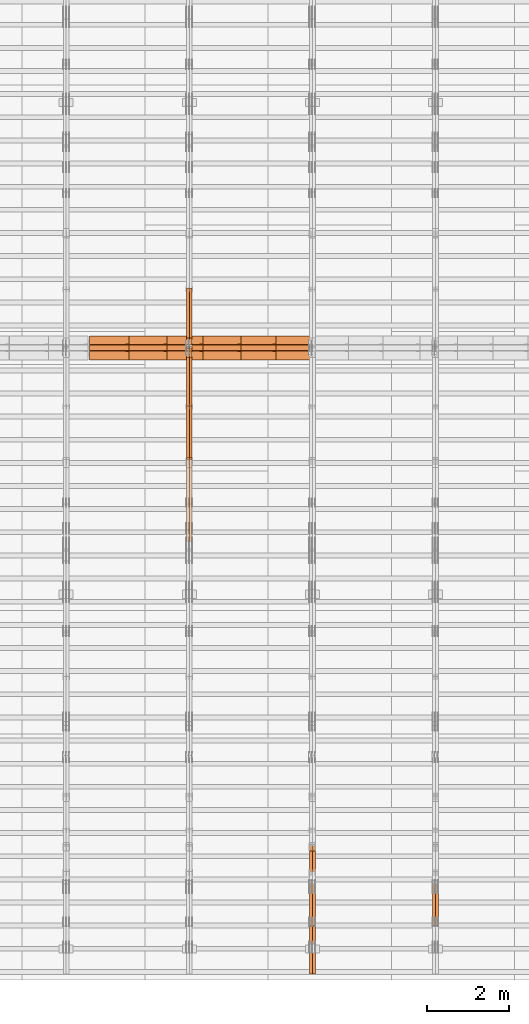
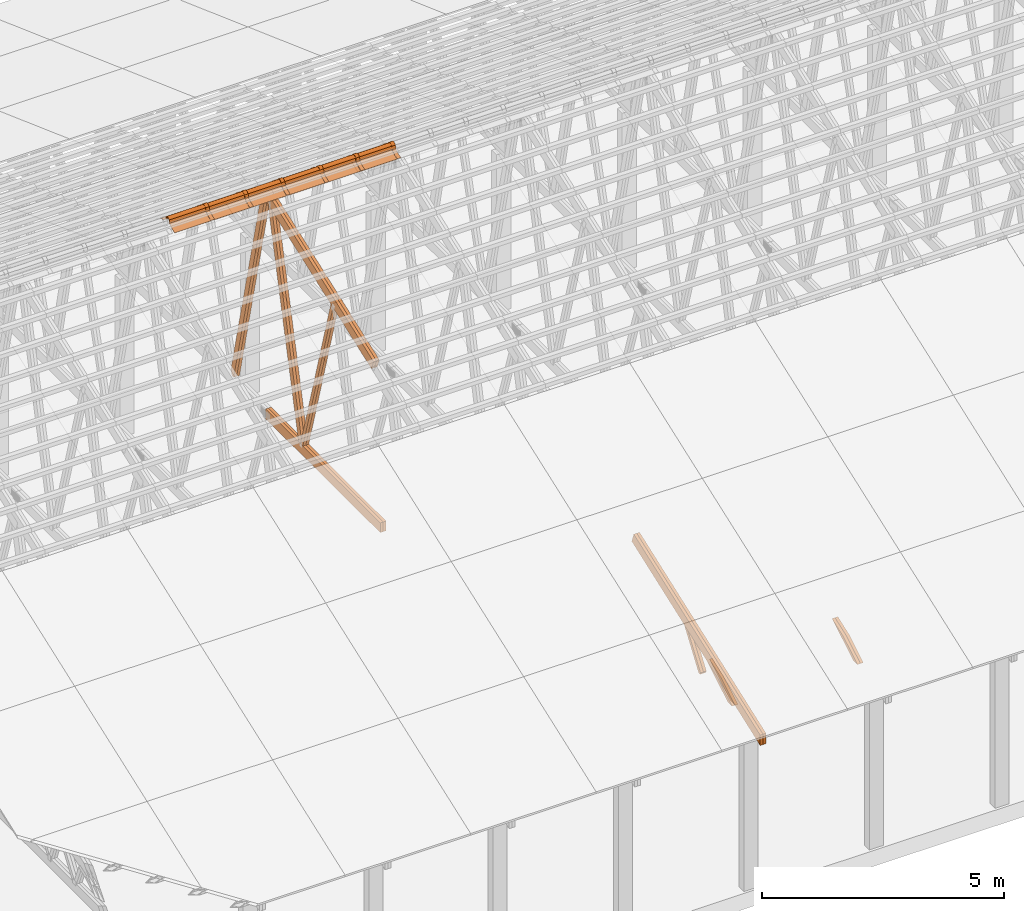
# One storey, part 20 of 189: 30 proxies.
"""IFC2X3 building model written with IfcOpenShell, lengths in millimetres."""

from ifc_helpers import new_model, entity, si_unit, converted_unit, derived_unit, direction, frame, frame_2d, origin, origin_2d_with_axis, place, context, subcontext, project, spatial, polyline, circle_curve, parameter, trimmed, segment, composite_curve, rectangle, outline, extrude, source, transform, mapped, material, type_object, type_shapes, element, save


model = new_model("IFC2X3")

# Units and contexts
model_context = context("Model", 3, precision=0.01, world=origin(), true_north=direction((6.12303176911189e-17, 1.0)))
body_context = subcontext(model_context, "Body", "Model", "MODEL_VIEW")
ifc_project = project(units=[si_unit("LENGTHUNIT", "METRE", prefix="MILLI"), si_unit("AREAUNIT", "SQUARE_METRE"), si_unit("VOLUMEUNIT", "CUBIC_METRE"), converted_unit("PLANEANGLEUNIT", "DEGREE", entity("IfcRatioMeasure", 0.0174532925199433), si_unit("PLANEANGLEUNIT", "RADIAN"), dimensions=[0, 0, 0, 0, 0, 0, 0]), si_unit("MASSUNIT", "GRAM", prefix="KILO"), derived_unit("MASSDENSITYUNIT", [(si_unit("MASSUNIT", "GRAM", prefix="KILO"), 1), (si_unit("LENGTHUNIT", "METRE"), -3)]), si_unit("TIMEUNIT", "SECOND"), si_unit("FREQUENCYUNIT", "HERTZ"), si_unit("THERMODYNAMICTEMPERATUREUNIT", "DEGREE_CELSIUS"), derived_unit("THERMALTRANSMITTANCEUNIT", [(si_unit("MASSUNIT", "GRAM", prefix="KILO"), 1), (si_unit("THERMODYNAMICTEMPERATUREUNIT", "KELVIN"), -1), (si_unit("TIMEUNIT", "SECOND"), -3)]), derived_unit("VOLUMETRICFLOWRATEUNIT", [(si_unit("LENGTHUNIT", "METRE"), 3), (si_unit("TIMEUNIT", "SECOND"), -1)]), si_unit("ELECTRICCURRENTUNIT", "AMPERE"), si_unit("ELECTRICVOLTAGEUNIT", "VOLT"), si_unit("POWERUNIT", "WATT"), si_unit("FORCEUNIT", "NEWTON"), si_unit("ILLUMINANCEUNIT", "LUX"), si_unit("LUMINOUSFLUXUNIT", "LUMEN"), si_unit("LUMINOUSINTENSITYUNIT", "CANDELA"), derived_unit("USERDEFINED", [(si_unit("MASSUNIT", "GRAM", prefix="KILO"), -1), (si_unit("LENGTHUNIT", "METRE"), -2), (si_unit("TIMEUNIT", "SECOND"), 3), (si_unit("LUMINOUSFLUXUNIT", "LUMEN"), 1)]), derived_unit("LINEARVELOCITYUNIT", [(si_unit("LENGTHUNIT", "METRE"), 1), (si_unit("TIMEUNIT", "SECOND"), -1)]), si_unit("PRESSUREUNIT", "PASCAL"), derived_unit("USERDEFINED", [(si_unit("LENGTHUNIT", "METRE"), -2), (si_unit("MASSUNIT", "GRAM", prefix="KILO"), 1), (si_unit("TIMEUNIT", "SECOND"), -2)])], contexts=[model_context])

# Site, building, storey
site_placement = place(None, origin())
site = spatial("IfcSite", under=ifc_project, at=site_placement, CompositionType="ELEMENT")
building_placement = place(site_placement, origin())
building = spatial("IfcBuilding", under=site, at=building_placement, CompositionType="ELEMENT")
storey_placement = place(building_placement, origin())
storey = spatial("IfcBuildingStorey", under=building, at=storey_placement, Name="Default", CompositionType="ELEMENT", Elevation=0.0)

# Proxies
ifc_material_1 = material(Name="IfcSurfaceStyle #96518")
building_element_proxy_type_1 = type_object("IfcBuildingElementProxyType", Name="T1-W12 96516", PredefinedType="NOTDEFINED", material=ifc_material_1)
shared_shape_1 = source(origin(), body_context, "Body", "SweptSolid", [
    extrude(outline(polyline([(-671.888430889784, -47.499785620702), (344.892972119224, -47.499785620702), (503.856463083211, 47.4997856207019), (-176.861004312651, 47.499785620702), (-671.888430889784, -47.499785620702)])), frame((503.857114243549, 47.5002636410509, 0.0), z_axis=(0.0, 0.0, 1.0), x_axis=(-1.0, 0.0, 0.0)), (0.0, 0.0, 1.0), 69.9999999999999),
])
type_shapes(building_element_proxy_type_1, [shared_shape_1])
proxy_1_placement = place(building_placement, frame((18300.0, 665.58122707747, 245.000076287477), z_axis=(-1.0, 0.0, 0.0), x_axis=(0.0, 0.858392121304013, 0.51299411895576)))
element("IfcBuildingElementProxy", 1, at=proxy_1_placement, inside=storey, type_object=building_element_proxy_type_1, material=ifc_material_1, Name="T1-W12", context=body_context, shape_type="MappedRepresentation", body=[
    mapped(shared_shape_1, transform((0.0, 0.0, 0.0), scale=1.0)),
])
ifc_material_2 = material(Name="IfcSurfaceStyle #96461")
building_element_proxy_type_2 = type_object("IfcBuildingElementProxyType", Name="T1-W12 96459", PredefinedType="NOTDEFINED", material=ifc_material_2)
shared_shape_2 = source(origin(), body_context, "Body", "SweptSolid", [
    extrude(outline(polyline([(-671.888430889784, -47.499785620702), (344.892972119224, -47.499785620702), (503.856463083211, 47.4997856207019), (-176.861004312651, 47.499785620702), (-671.888430889784, -47.499785620702)])), frame((503.857114243549, 47.5002636410509, 0.0), z_axis=(0.0, 0.0, 1.0), x_axis=(-1.0, 0.0, 0.0)), (0.0, 0.0, 1.0), 69.9999999999999),
])
type_shapes(building_element_proxy_type_2, [shared_shape_2])
proxy_2_placement = place(building_placement, frame((18230.0, 665.58122707747, 245.000076287477), z_axis=(-1.0, 0.0, 0.0), x_axis=(0.0, 0.858392121304013, 0.51299411895576)))
element("IfcBuildingElementProxy", 2, at=proxy_2_placement, inside=storey, type_object=building_element_proxy_type_2, material=ifc_material_2, Name="T1-W12", context=body_context, shape_type="MappedRepresentation", body=[
    mapped(shared_shape_2, transform((0.0, 0.0, 0.0), scale=1.0)),
])
ifc_material_3 = material(Name="IfcSurfaceStyle #81256")
building_element_proxy_type_3 = type_object("IfcBuildingElementProxyType", Name="T1-W13 81254", PredefinedType="NOTDEFINED", material=ifc_material_3)
shared_shape_3 = source(origin(), body_context, "Body", "SweptSolid", [
    extrude(outline(polyline([(404.740440720218, -341.48092914206), (570.336320797765, -341.48092914206), (-287.911826743206, 259.650691447848), (-342.395697357435, 239.820346030744), (-344.769237417342, 183.490820805529), (404.740440720218, -341.48092914206)])), frame((418.029573061951, 47.5005675782689, 0.0), z_axis=(0.0, 0.0, 1.0), x_axis=(0.819070847746389, 0.573692379565924, 0.0)), (0.0, 0.0, 1.0), 69.9999999999999),
])
type_shapes(building_element_proxy_type_3, [shared_shape_3])
proxy_3_placement = place(building_placement, frame((15300.0, 1951.16403402681, 272.239720286334), z_axis=(-1.0, 0.0, 0.0), x_axis=(0.0, 0.573462629043499, 0.819231721242848)))
element("IfcBuildingElementProxy", 3, at=proxy_3_placement, inside=storey, type_object=building_element_proxy_type_3, material=ifc_material_3, Name="T1-W13", context=body_context, shape_type="MappedRepresentation", body=[
    mapped(shared_shape_3, transform((0.0, 0.0, 0.0), scale=1.0)),
])
ifc_material_4 = material(Name="IfcSurfaceStyle #81190")
building_element_proxy_type_4 = type_object("IfcBuildingElementProxyType", Name="T1-W13 81188", PredefinedType="NOTDEFINED", material=ifc_material_4)
shared_shape_4 = source(origin(), body_context, "Body", "SweptSolid", [
    extrude(outline(polyline([(404.740440720218, -341.48092914206), (570.336320797765, -341.48092914206), (-287.911826743206, 259.650691447848), (-342.395697357435, 239.820346030744), (-344.769237417342, 183.490820805529), (404.740440720218, -341.48092914206)])), frame((418.029573061951, 47.5005675782689, 0.0), z_axis=(0.0, 0.0, 1.0), x_axis=(0.819070847746389, 0.573692379565924, 0.0)), (0.0, 0.0, 1.0), 69.9999999999999),
])
type_shapes(building_element_proxy_type_4, [shared_shape_4])
proxy_4_placement = place(building_placement, frame((15230.0, 1951.16403402681, 272.239720286334), z_axis=(-1.0, 0.0, 0.0), x_axis=(0.0, 0.573462629043499, 0.819231721242848)))
element("IfcBuildingElementProxy", 4, at=proxy_4_placement, inside=storey, type_object=building_element_proxy_type_4, material=ifc_material_4, Name="T1-W13", context=body_context, shape_type="MappedRepresentation", body=[
    mapped(shared_shape_4, transform((0.0, 0.0, 0.0), scale=1.0)),
])
ifc_material_5 = material(Name="IfcSurfaceStyle #80728")
building_element_proxy_type_5 = type_object("IfcBuildingElementProxyType", Name="T1-W12 80726", PredefinedType="NOTDEFINED", material=ifc_material_5)
shared_shape_5 = source(origin(), body_context, "Body", "SweptSolid", [
    extrude(outline(polyline([(-671.888430889784, -47.499785620702), (344.892972119224, -47.499785620702), (503.856463083211, 47.4997856207019), (-176.861004312651, 47.499785620702), (-671.888430889784, -47.499785620702)])), frame((503.857114243549, 47.5002636410509, 0.0), z_axis=(0.0, 0.0, 1.0), x_axis=(-1.0, 0.0, 0.0)), (0.0, 0.0, 1.0), 69.9999999999999),
])
type_shapes(building_element_proxy_type_5, [shared_shape_5])
proxy_5_placement = place(building_placement, frame((15300.0, 665.58122707747, 245.000076287477), z_axis=(-1.0, 0.0, 0.0), x_axis=(0.0, 0.858392121304013, 0.51299411895576)))
element("IfcBuildingElementProxy", 5, at=proxy_5_placement, inside=storey, type_object=building_element_proxy_type_5, material=ifc_material_5, Name="T1-W12", context=body_context, shape_type="MappedRepresentation", body=[
    mapped(shared_shape_5, transform((0.0, 0.0, 0.0), scale=1.0)),
])
ifc_material_6 = material(Name="IfcSurfaceStyle #80671")
building_element_proxy_type_6 = type_object("IfcBuildingElementProxyType", Name="T1-W12 80669", PredefinedType="NOTDEFINED", material=ifc_material_6)
shared_shape_6 = source(origin(), body_context, "Body", "SweptSolid", [
    extrude(outline(polyline([(-671.888430889784, -47.499785620702), (344.892972119224, -47.499785620702), (503.856463083211, 47.4997856207019), (-176.861004312651, 47.499785620702), (-671.888430889784, -47.499785620702)])), frame((503.857114243549, 47.5002636410509, 0.0), z_axis=(0.0, 0.0, 1.0), x_axis=(-1.0, 0.0, 0.0)), (0.0, 0.0, 1.0), 69.9999999999999),
])
type_shapes(building_element_proxy_type_6, [shared_shape_6])
proxy_6_placement = place(building_placement, frame((15230.0, 665.58122707747, 245.000076287477), z_axis=(-1.0, 0.0, 0.0), x_axis=(0.0, 0.858392121304013, 0.51299411895576)))
element("IfcBuildingElementProxy", 6, at=proxy_6_placement, inside=storey, type_object=building_element_proxy_type_6, material=ifc_material_6, Name="T1-W12", context=body_context, shape_type="MappedRepresentation", body=[
    mapped(shared_shape_6, transform((0.0, 0.0, 0.0), scale=1.0)),
])
ifc_material_7 = material(Name="IfcSurfaceStyle #79780")
building_element_proxy_type_7 = type_object("IfcBuildingElementProxyType", Name="T1-T2 79778", PredefinedType="NOTDEFINED", material=ifc_material_7)
shared_shape_7 = source(origin(), body_context, "Body", "SweptSolid", [
    extrude(outline(polyline([(-2763.12044548193, -122.499971764318), (2807.70681121203, -122.499971764318), (2807.70678531127, 122.499971764318), (-2852.29315104137, 122.499971764318), (-2763.12044548193, -122.499971764318)])), frame((2807.70684902043, 122.500023191939, 0.0), z_axis=(0.0, 0.0, 1.0), x_axis=(-1.0, 0.0, 0.0)), (0.0, 0.0, 1.0), 69.9999999999997),
])
type_shapes(building_element_proxy_type_7, [shared_shape_7])
proxy_7_placement = place(building_placement, frame((15300.0, 4818.66023370631, 1893.1253396746), z_axis=(-1.0, 0.0, 0.0), x_axis=(0.0, -0.939692620785908, -0.342020143325669)))
element("IfcBuildingElementProxy", 7, at=proxy_7_placement, inside=storey, type_object=building_element_proxy_type_7, material=ifc_material_7, Name="T1-T2", context=body_context, shape_type="MappedRepresentation", body=[
    mapped(shared_shape_7, transform((0.0, 0.0, 0.0), scale=1.0)),
])
ifc_material_8 = material(Name="IfcSurfaceStyle #79723")
building_element_proxy_type_8 = type_object("IfcBuildingElementProxyType", Name="T1-T2 79721", PredefinedType="NOTDEFINED", material=ifc_material_8)
shared_shape_8 = source(origin(), body_context, "Body", "SweptSolid", [
    extrude(outline(polyline([(-2763.12044548193, -122.499971764318), (2807.70681121203, -122.499971764318), (2807.70678531127, 122.499971764318), (-2852.29315104137, 122.499971764318), (-2763.12044548193, -122.499971764318)])), frame((2807.70684902043, 122.500023191939, 0.0), z_axis=(0.0, 0.0, 1.0), x_axis=(-1.0, 0.0, 0.0)), (0.0, 0.0, 1.0), 69.9999999999997),
])
type_shapes(building_element_proxy_type_8, [shared_shape_8])
proxy_8_placement = place(building_placement, frame((15230.0, 4818.66023370631, 1893.1253396746), z_axis=(-1.0, 0.0, 0.0), x_axis=(0.0, -0.939692620785908, -0.342020143325669)))
element("IfcBuildingElementProxy", 8, at=proxy_8_placement, inside=storey, type_object=building_element_proxy_type_8, material=ifc_material_8, Name="T1-T2", context=body_context, shape_type="MappedRepresentation", body=[
    mapped(shared_shape_8, transform((0.0, 0.0, 0.0), scale=1.0)),
])
ifc_material_9 = material(Name="IfcSurfaceStyle #68634")
building_element_proxy_type_9 = type_object("IfcBuildingElementProxyType", Name="T1-W5 68632", PredefinedType="NOTDEFINED", material=ifc_material_9)
shared_shape_9 = source(origin(), body_context, "Body", "SweptSolid", [
    extrude(outline(polyline([(-3233.61216530572, -72.4999091305202), (2153.79187521892, -72.4999091305202), (2171.36968478227, -7.18521572819375e-05), (2045.62106208646, 72.4999450565989), (-3137.17045678193, 72.4999450565989), (-3233.61216530572, -72.4999091305202)])), frame((2171.36968478227, 72.500192121173, 0.0), z_axis=(0.0, 0.0, 1.0), x_axis=(-1.0, 0.0, 0.0)), (0.0, 0.0, 1.0), 69.9999999999997),
])
type_shapes(building_element_proxy_type_9, [shared_shape_9])
proxy_9_placement = place(building_placement, frame((12300.0, 13261.0146935344, 262.082919891325), z_axis=(-1.0, 0.0, 0.0), x_axis=(0.0, 0.235625623344066, 0.97184389982328)))
element("IfcBuildingElementProxy", 9, at=proxy_9_placement, inside=storey, type_object=building_element_proxy_type_9, material=ifc_material_9, Name="T1-W5", context=body_context, shape_type="MappedRepresentation", body=[
    mapped(shared_shape_9, transform((0.0, 0.0, 0.0), scale=1.0)),
])
ifc_material_10 = material(Name="IfcSurfaceStyle #68568")
building_element_proxy_type_10 = type_object("IfcBuildingElementProxyType", Name="T1-W5 68566", PredefinedType="NOTDEFINED", material=ifc_material_10)
shared_shape_10 = source(origin(), body_context, "Body", "SweptSolid", [
    extrude(outline(polyline([(-3233.61216530572, -72.4999091305202), (2153.79187521892, -72.4999091305202), (2171.36968478227, -7.18521572819375e-05), (2045.62106208646, 72.4999450565989), (-3137.17045678193, 72.4999450565989), (-3233.61216530572, -72.4999091305202)])), frame((2171.36968478227, 72.500192121173, 0.0), z_axis=(0.0, 0.0, 1.0), x_axis=(-1.0, 0.0, 0.0)), (0.0, 0.0, 1.0), 69.9999999999997),
])
type_shapes(building_element_proxy_type_10, [shared_shape_10])
proxy_10_placement = place(building_placement, frame((12230.0, 13261.0146935344, 262.082919891325), z_axis=(-1.0, 0.0, 0.0), x_axis=(0.0, 0.235625623344066, 0.97184389982328)))
element("IfcBuildingElementProxy", 10, at=proxy_10_placement, inside=storey, type_object=building_element_proxy_type_10, material=ifc_material_10, Name="T1-W5", context=body_context, shape_type="MappedRepresentation", body=[
    mapped(shared_shape_10, transform((0.0, 0.0, 0.0), scale=1.0)),
])
ifc_material_11 = material(Name="IfcSurfaceStyle #68502")
building_element_proxy_type_11 = type_object("IfcBuildingElementProxyType", Name="T1-W5 68500", PredefinedType="NOTDEFINED", material=ifc_material_11)
shared_shape_11 = source(origin(), body_context, "Body", "SweptSolid", [
    extrude(outline(polyline([(-3137.17045678193, -72.5002081306407), (2045.62106208646, -72.5002081306408), (2171.36968478227, 5.58426931168476e-05), (2153.79187521892, 72.5001802092942), (-3233.61216530572, 72.5001802092942), (-3137.17045678193, -72.5002081306407)])), frame((2171.36968478227, 72.5001802092942, 0.0), z_axis=(0.0, 0.0, 1.0), x_axis=(-1.0, 0.0, 0.0)), (0.0, 0.0, 1.0), 69.9999999999997),
])
type_shapes(building_element_proxy_type_11, [shared_shape_11])
proxy_11_placement = place(building_placement, frame((12300.0, 16098.0675635854, 227.917113003597), z_axis=(-1.0, 0.0, 0.0), x_axis=(0.0, -0.235625623344066, 0.971843899823279)))
element("IfcBuildingElementProxy", 11, at=proxy_11_placement, inside=storey, type_object=building_element_proxy_type_11, material=ifc_material_11, Name="T1-W5", context=body_context, shape_type="MappedRepresentation", body=[
    mapped(shared_shape_11, transform((0.0, 0.0, 0.0), scale=1.0)),
])
ifc_material_12 = material(Name="IfcSurfaceStyle #68436")
building_element_proxy_type_12 = type_object("IfcBuildingElementProxyType", Name="T1-W5 68434", PredefinedType="NOTDEFINED", material=ifc_material_12)
shared_shape_12 = source(origin(), body_context, "Body", "SweptSolid", [
    extrude(outline(polyline([(-3137.17045678193, -72.5002081306407), (2045.62106208646, -72.5002081306408), (2171.36968478227, 5.58426931168476e-05), (2153.79187521892, 72.5001802092942), (-3233.61216530572, 72.5001802092942), (-3137.17045678193, -72.5002081306407)])), frame((2171.36968478227, 72.5001802092942, 0.0), z_axis=(0.0, 0.0, 1.0), x_axis=(-1.0, 0.0, 0.0)), (0.0, 0.0, 1.0), 69.9999999999997),
])
type_shapes(building_element_proxy_type_12, [shared_shape_12])
proxy_12_placement = place(building_placement, frame((12230.0, 16098.0675635854, 227.917113003597), z_axis=(-1.0, 0.0, 0.0), x_axis=(0.0, -0.235625623344066, 0.971843899823279)))
element("IfcBuildingElementProxy", 12, at=proxy_12_placement, inside=storey, type_object=building_element_proxy_type_12, material=ifc_material_12, Name="T1-W5", context=body_context, shape_type="MappedRepresentation", body=[
    mapped(shared_shape_12, transform((0.0, 0.0, 0.0), scale=1.0)),
])
ifc_material_13 = material(Name="IfcSurfaceStyle #68370")
building_element_proxy_type_13 = type_object("IfcBuildingElementProxyType", Name="T1-W6 68368", PredefinedType="NOTDEFINED", material=ifc_material_13)
shared_shape_13 = source(origin(), body_context, "Body", "SweptSolid", [
    extrude(outline(polyline([(-2640.84340836012, -47.4996765865792), (1711.12245024294, -47.4996765865792), (1797.68490303083, -9.57690019346202e-05), (1800.72595169379, 47.4997244710801), (-2668.68989660745, 47.4997244710801), (-2640.84340836012, -47.4996765865792)])), frame((1800.72595169379, 47.5003009358159, 0.0), z_axis=(0.0, 0.0, 1.0), x_axis=(-1.0, 0.0, 0.0)), (0.0, 0.0, 1.0), 69.9999999999997),
])
type_shapes(building_element_proxy_type_13, [shared_shape_13])
proxy_13_placement = place(building_placement, frame((12300.0, 12074.2896156894, 4533.9586582452), z_axis=(-1.0, 0.0, 0.0), x_axis=(0.0, 0.28128598310461, -0.959623986626467)))
element("IfcBuildingElementProxy", 13, at=proxy_13_placement, inside=storey, type_object=building_element_proxy_type_13, material=ifc_material_13, Name="T1-W6", context=body_context, shape_type="MappedRepresentation", body=[
    mapped(shared_shape_13, transform((0.0, 0.0, 0.0), scale=1.0)),
])
ifc_material_14 = material(Name="IfcSurfaceStyle #68304")
building_element_proxy_type_14 = type_object("IfcBuildingElementProxyType", Name="T1-W6 68302", PredefinedType="NOTDEFINED", material=ifc_material_14)
shared_shape_14 = source(origin(), body_context, "Body", "SweptSolid", [
    extrude(outline(polyline([(-2640.84340836012, -47.4996765865792), (1711.12245024294, -47.4996765865792), (1797.68490303083, -9.57690019346202e-05), (1800.72595169379, 47.4997244710801), (-2668.68989660745, 47.4997244710801), (-2640.84340836012, -47.4996765865792)])), frame((1800.72595169379, 47.5003009358159, 0.0), z_axis=(0.0, 0.0, 1.0), x_axis=(-1.0, 0.0, 0.0)), (0.0, 0.0, 1.0), 69.9999999999997),
])
type_shapes(building_element_proxy_type_14, [shared_shape_14])
proxy_14_placement = place(building_placement, frame((12230.0, 12074.2896156894, 4533.9586582452), z_axis=(-1.0, 0.0, 0.0), x_axis=(0.0, 0.28128598310461, -0.959623986626467)))
element("IfcBuildingElementProxy", 14, at=proxy_14_placement, inside=storey, type_object=building_element_proxy_type_14, material=ifc_material_14, Name="T1-W6", context=body_context, shape_type="MappedRepresentation", body=[
    mapped(shared_shape_14, transform((0.0, 0.0, 0.0), scale=1.0)),
])
ifc_material_15 = material(Name="IfcSurfaceStyle #64350")
building_element_proxy_type_15 = type_object("IfcBuildingElementProxyType", Name="T1-B3 64348", PredefinedType="NOTDEFINED", material=ifc_material_15)
shared_shape_15 = source(origin(), body_context, "Body", "SweptSolid", [
    extrude(rectangle(XDim=4751.0283203125, YDim=245.000000000001, at=origin_2d_with_axis()), frame((2375.51416015625, 122.5, 0.0), z_axis=(0.0, 0.0, 1.0), x_axis=(-1.0, 0.0, 0.0)), (0.0, 0.0, 1.0), 69.9999999999997),
])
type_shapes(building_element_proxy_type_15, [shared_shape_15])
proxy_15_placement = place(building_placement, frame((12300.0, 10029.23046875, 245.0), z_axis=(-1.0, 0.0, 0.0), x_axis=(0.0, 1.0, 0.0)))
element("IfcBuildingElementProxy", 15, at=proxy_15_placement, inside=storey, type_object=building_element_proxy_type_15, material=ifc_material_15, Name="T1-B3", context=body_context, shape_type="MappedRepresentation", body=[
    mapped(shared_shape_15, transform((0.0, 0.0, 0.0), scale=1.0)),
])
ifc_material_16 = material(Name="IfcSurfaceStyle #64293")
building_element_proxy_type_16 = type_object("IfcBuildingElementProxyType", Name="T1-B3 64291", PredefinedType="NOTDEFINED", material=ifc_material_16)
shared_shape_16 = source(origin(), body_context, "Body", "SweptSolid", [
    extrude(rectangle(XDim=4751.0283203125, YDim=245.000000000001, at=origin_2d_with_axis()), frame((2375.51416015625, 122.5, 0.0), z_axis=(0.0, 0.0, 1.0), x_axis=(-1.0, 0.0, 0.0)), (0.0, 0.0, 1.0), 69.9999999999997),
])
type_shapes(building_element_proxy_type_16, [shared_shape_16])
proxy_16_placement = place(building_placement, frame((12230.0, 10029.23046875, 245.0), z_axis=(-1.0, 0.0, 0.0), x_axis=(0.0, 1.0, 0.0)))
element("IfcBuildingElementProxy", 16, at=proxy_16_placement, inside=storey, type_object=building_element_proxy_type_16, material=ifc_material_16, Name="T1-B3", context=body_context, shape_type="MappedRepresentation", body=[
    mapped(shared_shape_16, transform((0.0, 0.0, 0.0), scale=1.0)),
])
ifc_material_17 = material(Name="IfcSurfaceStyle #63762")
building_element_proxy_type_17 = type_object("IfcBuildingElementProxyType", Name="T1-T3 63760", PredefinedType="NOTDEFINED", material=ifc_material_17)
shared_shape_17 = source(origin(), body_context, "Body", "SweptSolid", [
    extrude(outline(polyline([(-2341.64890001385, -122.499972785692), (2386.23525922045, -122.499972785692), (2297.06252495753, 122.499972785692), (-2341.64888416412, 122.499972785692), (-2341.64890001385, -122.499972785692)])), frame((2386.23525922045, 122.499973888764, 0.0), z_axis=(0.0, 0.0, 1.0), x_axis=(-1.0, 0.0, 0.0)), (0.0, 0.0, 1.0), 69.9999999999997),
])
type_shapes(building_element_proxy_type_17, [shared_shape_17])
proxy_17_placement = place(building_placement, frame((12300.0, 14833.7949607394, 5538.33627266055), z_axis=(-1.0, 0.0, 0.0), x_axis=(0.0, -0.939692620785908, -0.342020143325669)))
element("IfcBuildingElementProxy", 17, at=proxy_17_placement, inside=storey, type_object=building_element_proxy_type_17, material=ifc_material_17, Name="T1-T3", context=body_context, shape_type="MappedRepresentation", body=[
    mapped(shared_shape_17, transform((0.0, 0.0, 0.0), scale=1.0)),
])
ifc_material_18 = material(Name="IfcSurfaceStyle #63705")
building_element_proxy_type_18 = type_object("IfcBuildingElementProxyType", Name="T1-T3 63703", PredefinedType="NOTDEFINED", material=ifc_material_18)
shared_shape_18 = source(origin(), body_context, "Body", "SweptSolid", [
    extrude(outline(polyline([(-2341.64890001385, -122.499972785692), (2386.23525922045, -122.499972785692), (2297.06252495753, 122.499972785692), (-2341.64888416412, 122.499972785692), (-2341.64890001385, -122.499972785692)])), frame((2386.23525922045, 122.499973888764, 0.0), z_axis=(0.0, 0.0, 1.0), x_axis=(-1.0, 0.0, 0.0)), (0.0, 0.0, 1.0), 69.9999999999997),
])
type_shapes(building_element_proxy_type_18, [shared_shape_18])
proxy_18_placement = place(building_placement, frame((12230.0, 14833.7949607394, 5538.33627266055), z_axis=(-1.0, 0.0, 0.0), x_axis=(0.0, -0.939692620785908, -0.342020143325669)))
element("IfcBuildingElementProxy", 18, at=proxy_18_placement, inside=storey, type_object=building_element_proxy_type_18, material=ifc_material_18, Name="T1-T3", context=body_context, shape_type="MappedRepresentation", body=[
    mapped(shared_shape_18, transform((0.0, 0.0, 0.0), scale=1.0)),
])
ifc_material_19 = material()
building_element_proxy_type_19 = type_object("IfcBuildingElementProxyType", Name="P75", PredefinedType="NOTDEFINED", material=ifc_material_19)
shared_shape_19 = source(origin(), body_context, "Body", "SweptSolid", [
    extrude(outline(composite_curve([segment(polyline([(-69.4623915065845, -4.60763114971976), (47.4521071665907, -4.60763114971981)]), True, "CONTINUOUS"), segment(trimmed(circle_curve(frame_2d((119.940978060963, 14.6372018310859), x_axis=(-0.966518278591622, -0.256597773077395)), 75.0), [parameter(6.61555373744412e-13)], [parameter(180.0)], True, "PARAMETER"), True, "CONTINUOUS"), segment(polyline([(192.429848955335, 33.882034811891), (182.764666169419, 31.3160570811166)]), True, "CONTINUOUS"), segment(trimmed(circle_curve(frame_2d((119.940978060963, 14.6372018310859), x_axis=(-0.966518278591622, -0.256597773077395)), 65.0), [parameter(1.06866637297174e-12)], [parameter(180.0)], True, "PARAMETER"), False, "CONTINUOUS"), segment(polyline([(57.1172899525073, -2.04165341894578), (47.4521071665911, 5.39236885028051)]), True, "CONTINUOUS"), segment(polyline([(47.4521071665911, 5.39236885028052), (-70.7672243976422, 5.39236885028094)]), True, "CONTINUOUS"), segment(polyline([(-70.7672243976422, 5.39236885028094), (-194.776190618495, -27.5303655446341)]), True, "CONTINUOUS"), segment(polyline([(-194.776190618495, -27.5303655446341), (-192.210212887721, -37.1955483305503)]), True, "CONTINUOUS"), segment(polyline([(-192.210212887721, -37.1955483305503), (-69.4623915065845, -4.60763114971974)]), True, "CONTINUOUS")], self_intersect=False)), frame((0.0, 106.775760402721, -56.5599052870917), z_axis=(1.0, 0.0, 0.0), x_axis=(0.0, -0.820468487122275, 0.571691754041709)), (0.0, 0.0, 1.0), 867.000000000001),
    extrude(outline(composite_curve([segment(polyline([(62.2906866429439, -18.428943356533), (189.290686642944, -18.428943356533)]), True, "CONTINUOUS"), segment(polyline([(189.290686642944, -18.428943356533), (189.290686642944, -8.42894335653292)]), True, "CONTINUOUS"), segment(polyline([(189.290686642944, -8.42894335653292), (62.2906866429439, -8.42894335653294)]), True, "CONTINUOUS"), segment(polyline([(62.2906866429439, -8.42894335653294), (-41.0348065006093, 19.0026034957362)]), True, "CONTINUOUS"), segment(trimmed(circle_curve(frame_2d((-125.709313357056, 11.5710566434651), x_axis=(1.0, 0.0)), 85.0), [parameter(5.01577186738723)], [parameter(180.0)], True, "PARAMETER"), True, "CONTINUOUS"), segment(polyline([(-210.709313357056, 11.5710566434656), (-200.709313357056, 11.5710566434656)]), True, "CONTINUOUS"), segment(trimmed(circle_curve(frame_2d((-125.709313357056, 11.5710566434651), x_axis=(1.0, 0.0)), 75.0), [parameter(3.05333249420498e-13)], [parameter(180.0)], True, "PARAMETER"), False, "CONTINUOUS"), segment(polyline([(-50.7093133570542, 11.5710566434655), (62.290686642944, -18.4289433565322)]), True, "CONTINUOUS")], self_intersect=False)), frame((867.0, 114.170579674061, -53.8683539143053), z_axis=(1.0, 0.0, 0.0), x_axis=(0.0, 0.939692620785914, -0.342020143325653)), (0.0, 0.0, 1.0), 86.9999999999998),
])
type_shapes(building_element_proxy_type_19, [shared_shape_19])
for number, where, name in (
    (19, (14252.9353253273, 14755.0000438631, 5865.69618295448), "P75, generic model20:P75"),
    (20, (13392.9353253273, 14755.0000438631, 5865.69618295448), "P75, generic model20:P75"),
    (21, (12532.9353253273, 14755.0000438632, 5865.69618295448), "P75, generic model20:P75"),
    (22, (11612.9353253273, 14755.0000438632, 5865.69618295448), "P75, generic model20:P75"),
    (23, (10732.9353253273, 14755.0000438632, 5865.69618295448), "P75, generic model20:P75"),
    (24, (9803.91649737545, 14755.0000438632, 5865.69618295448), "P75, generic model20:P75"),
):
    element("IfcBuildingElementProxy", number, at=place(storey_placement, frame(where)), inside=storey, type_object=building_element_proxy_type_19, material=ifc_material_19, Name=name, ObjectType="P75, generic model20:P75", context=body_context, shape_type="MappedRepresentation", body=[
        mapped(shared_shape_19, transform((0.0, 0.0, 0.0), scale=1.0)),
    ])
building_element_proxy_type_20 = type_object("IfcBuildingElementProxyType", Name="P75", PredefinedType="NOTDEFINED", material=ifc_material_19)
shared_shape_20 = source(origin(), body_context, "Body", "SweptSolid", [
    extrude(outline(composite_curve([segment(polyline([(68.3189789579817, 13.3705352460084), (195.318978957982, 13.3705352460084)]), True, "CONTINUOUS"), segment(polyline([(195.318978957982, 13.3705352460084), (195.318978957982, 23.3705352460084)]), True, "CONTINUOUS"), segment(polyline([(195.318978957982, 23.3705352460084), (67.014146066922, 23.3705352460088)]), True, "CONTINUOUS"), segment(polyline([(67.014146066922, 23.3705352460088), (-47.2469987727929, -6.96428196807339)]), True, "CONTINUOUS"), segment(polyline([(-47.2469987727929, -6.96428196807339), (-54.6810210420187, -16.62946475399)]), True, "CONTINUOUS"), segment(trimmed(circle_curve(frame_2d((-119.681021042019, -16.6294647539896), x_axis=(1.0, 0.0)), 65.0), [parameter(180.0)], [parameter(359.999999999999)], True, "PARAMETER"), False, "CONTINUOUS"), segment(polyline([(-184.681021042019, -16.6294647539905), (-194.681021042019, -16.6294647539901)]), True, "CONTINUOUS"), segment(trimmed(circle_curve(frame_2d((-119.681021042019, -16.6294647539896), x_axis=(1.0, 0.0)), 75.0), [parameter(180.0)], [parameter(359.999999999999)], True, "PARAMETER"), True, "CONTINUOUS"), segment(polyline([(-44.6810210420183, -16.6294647539898), (68.3189789579816, 13.3705352460083)]), True, "CONTINUOUS")], self_intersect=False)), frame((0.0, -106.775760402721, -56.5599052870916), z_axis=(1.0, 0.0, 0.0), x_axis=(0.0, -0.939692620785914, -0.342020143325654)), (0.0, 0.0, 1.0), 867.000000000001),
    extrude(outline(composite_curve([segment(polyline([(-64.9339130518847, 1.82825913317695), (-187.681734433021, -30.7596580476538)]), True, "CONTINUOUS"), segment(polyline([(-187.681734433021, -30.7596580476538), (-185.115756702247, -40.4248408335702)]), True, "CONTINUOUS"), segment(polyline([(-185.115756702247, -40.4248408335702), (-62.3679353211107, -7.83692365273935)]), True, "CONTINUOUS"), segment(polyline([(-62.3679353211107, -7.83692365273935), (44.5369162809878, -7.83692365273935)]), True, "CONTINUOUS"), segment(trimmed(circle_curve(frame_2d((124.469456515662, 21.0730921139827), x_axis=(-0.966518278591636, -0.256597773077402)), 85.0), [parameter(5.01577186738723)], [parameter(180.0)], True, "PARAMETER"), True, "CONTINUOUS"), segment(polyline([(206.623510195951, 42.8839028255618), (196.958327410034, 40.3179250947878)]), True, "CONTINUOUS"), segment(trimmed(circle_curve(frame_2d((124.469456515662, 21.0730921139827), x_axis=(-0.966518278591636, -0.256597773077402)), 75.0), [parameter(3.05333249420498e-13)], [parameter(180.0)], True, "PARAMETER"), False, "CONTINUOUS"), segment(polyline([(51.9805856212887, 1.82825913317622), (-64.9339130518846, 1.82825913317621)]), True, "CONTINUOUS")], self_intersect=False)), frame((867.0, -114.170579674061, -53.868353914305), z_axis=(-1.0, 0.0, 0.0), x_axis=(0.0, 0.820468487122275, 0.571691754041709)), (0.0, 0.0, -1.0), 86.9999999999998),
])
type_shapes(building_element_proxy_type_20, [shared_shape_20])
for number, where, name in (
    (25, (14252.9353253273, 14745.0000384614, 5850.69618295448), "P75, generic model20:P75"),
    (26, (13392.9353253273, 14745.0000384614, 5850.69618295448), "P75, generic model20:P75"),
    (27, (12532.9353253273, 14745.0000384614, 5850.69618295448), "P75, generic model20:P75"),
    (28, (11612.9353253273, 14745.0000384614, 5850.69618295448), "P75, generic model20:P75"),
    (29, (10732.9353253273, 14745.0000384614, 5850.69618295448), "P75, generic model20:P75"),
    (30, (9803.91649737545, 14745.0000384614, 5850.69618295448), "P75, generic model20:P75"),
):
    element("IfcBuildingElementProxy", number, at=place(storey_placement, frame(where)), inside=storey, type_object=building_element_proxy_type_20, material=ifc_material_19, Name=name, ObjectType="P75, generic model20:P75", context=body_context, shape_type="MappedRepresentation", body=[
        mapped(shared_shape_20, transform((0.0, 0.0, 0.0), scale=1.0)),
    ])

save(model, "model.ifc")
